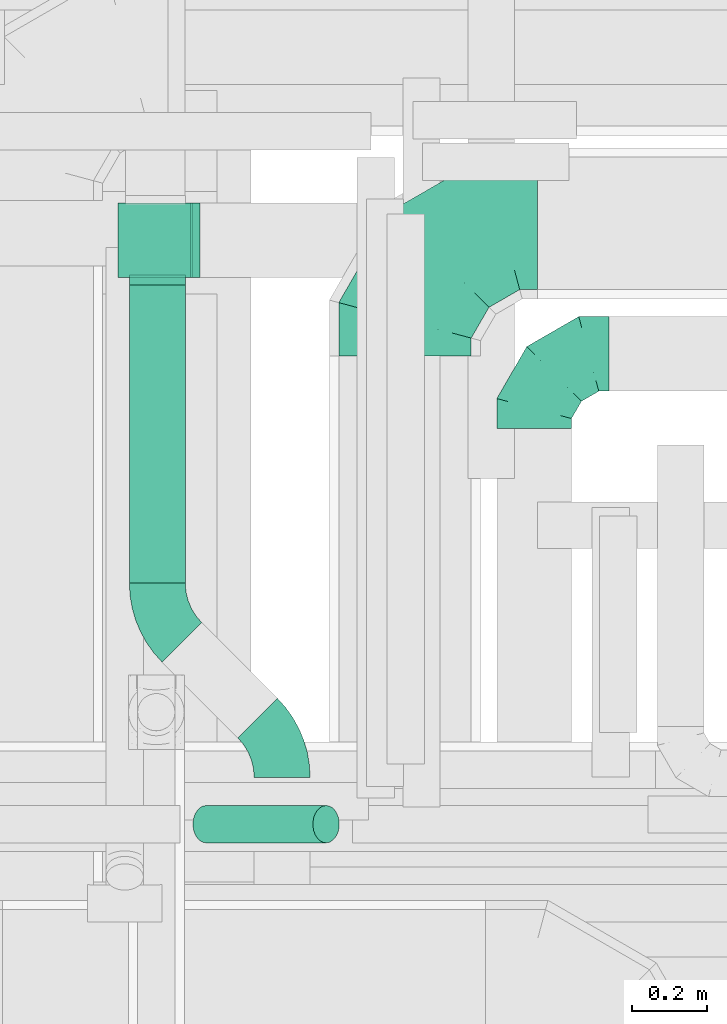
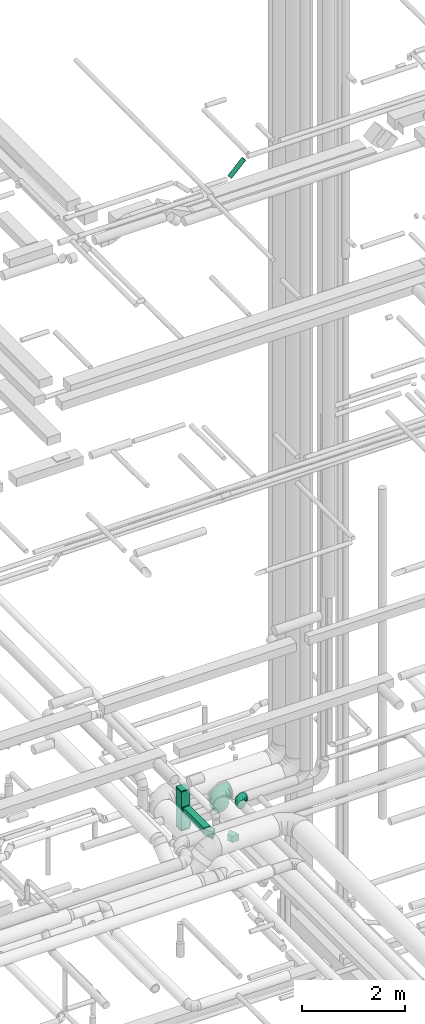
# One storey, part 256 of 337: 8 flow fittings, 3 flow segments.
"""IFC2X3 building model written with IfcOpenShell, lengths in millimetres."""

import ifcopenshell
import ifcopenshell.guid

model = None  # the IFC model being written
_history = None  # IfcOwnerHistory: only IFC2X3 demands one
_inside = {}  # id of a spatial element -> (the spatial element, [elements in it])
_under = {}  # id of a project, library or spatial element -> (it, [spatial elements below it])
_declared = {}  # id of a project -> (the project, [libraries it declares])
_typed = {}  # id of a type object -> (the type object, [elements of that type])
_made_of = {}  # id of a material, layer set ... -> (it, [elements and type objects made of it])


def new_model(schema):
    """Start an empty IFC model of exactly this schema.

    Asked for "IFC4X3", IfcOpenShell would pick the latest addendum, in which some entities
    have other attributes; the version numbers below select the first issue.
    IFC2X3 requires an IfcOwnerHistory on every rooted entity: one is made here for all.
    """
    global model, _history
    if schema == "IFC4X3":
        model = ifcopenshell.file(schema_version=(4, 3, 0, 0))
    else:
        model = ifcopenshell.file(schema=schema)
    _inside.clear()
    _under.clear()
    _declared.clear()
    _typed.clear()
    _made_of.clear()
    _history = None
    if model.schema == "IFC2X3":
        org = make("IfcOrganization", Name="unknown")
        user = make(
            "IfcPersonAndOrganization",
            ThePerson=make("IfcPerson", FamilyName="unknown"),
            TheOrganization=org,
        )
        app = make(
            "IfcApplication",
            ApplicationDeveloper=org,
            Version="unknown",
            ApplicationFullName="unknown",
            ApplicationIdentifier="unknown",
        )
        _history = make(
            "IfcOwnerHistory",
            OwningUser=user,
            OwningApplication=app,
            ChangeAction="ADDED",
            CreationDate=0,
        )
    return model


def make(cls, **values):
    """One entity of the class cls with the attributes given. An attribute that is None is left unset."""
    return model.create_entity(
        cls, **{name: value for name, value in values.items() if value is not None}
    )


def entity(cls, *values):
    """Any entity or typed value of the class cls, its attributes in the order of the schema. None: left unset."""
    e = model.create_entity(cls)
    for i, value in enumerate(values):
        if value is not None:
            e[i] = value
    return e


def rooted(cls, **values):
    """An entity with a GlobalId (a new one), such as an element, a storey or a relation."""
    return make(cls, GlobalId=ifcopenshell.guid.new(), OwnerHistory=_history, **values)


def si_unit(unit_type, name, prefix=None):
    """IfcSIUnit, for example si_unit("LENGTHUNIT", "METRE", prefix="MILLI")."""
    return make("IfcSIUnit", UnitType=unit_type, Prefix=prefix, Name=name)


def converted_unit(unit_type, name, factor, base, dimensions=None, offset=None):
    """IfcConversionBasedUnit, such as the inch: factor (a typed value) times the base unit."""
    return make(
        "IfcConversionBasedUnit"
        if offset is None
        else "IfcConversionBasedUnitWithOffset",
        ConversionOffset=offset,
        Dimensions=None
        if dimensions is None
        else entity("IfcDimensionalExponents", *dimensions),
        UnitType=unit_type,
        Name=name,
        ConversionFactor=make(
            "IfcMeasureWithUnit", ValueComponent=factor, UnitComponent=base
        ),
    )


def derived_unit(unit_type, elements):
    """IfcDerivedUnit: a product of units, each with its exponent."""
    return make(
        "IfcDerivedUnit",
        Elements=[
            make("IfcDerivedUnitElement", Unit=unit, Exponent=power)
            for unit, power in elements
        ],
        UnitType=unit_type,
    )


def assignment(units):
    """IfcUnitAssignment: the units of a project."""
    return None if units is None else make("IfcUnitAssignment", Units=units)


def point(xyz):
    """IfcCartesianPoint."""
    return None if xyz is None else make("IfcCartesianPoint", Coordinates=xyz)


def direction(xyz):
    """IfcDirection."""
    return None if xyz is None else make("IfcDirection", DirectionRatios=xyz)


def frame(location, z_axis=None, x_axis=None):
    """IfcAxis2Placement3D, a coordinate frame: its origin and axes. An axis left out is left unset."""
    return make(
        "IfcAxis2Placement3D",
        Location=point(location),
        Axis=direction(z_axis),
        RefDirection=direction(x_axis),
    )


def frame_2d(location, x_axis=None):
    """IfcAxis2Placement2D, a coordinate frame in the plane: its origin and x axis."""
    return make(
        "IfcAxis2Placement2D", Location=point(location), RefDirection=direction(x_axis)
    )


def origin():
    """The frame at (0, 0, 0) with its axes left unset."""
    return frame((0.0, 0.0, 0.0))


def origin_2d_with_axis():
    """The frame at (0, 0) in the plane with the x axis (1, 0) written out."""
    return frame_2d((0.0, 0.0), x_axis=(1.0, 0.0))


def place(relative_to, where):
    """IfcLocalPlacement: puts the frame where relative to a parent placement (None: the world)."""
    return make(
        "IfcLocalPlacement", PlacementRelTo=relative_to, RelativePlacement=where
    )


def context(
    kind, dimensions, precision=None, world=None, true_north=None, identifier=None
):
    """IfcGeometricRepresentationContext, for example the 3D "Model" context."""
    return make(
        "IfcGeometricRepresentationContext",
        ContextIdentifier=identifier,
        ContextType=kind,
        CoordinateSpaceDimension=dimensions,
        Precision=precision,
        WorldCoordinateSystem=world,
        TrueNorth=true_north,
    )


def subcontext(parent, identifier, kind, view, scale=None):
    """IfcGeometricRepresentationSubContext, for example "Body" below "Model"."""
    return make(
        "IfcGeometricRepresentationSubContext",
        ContextIdentifier=identifier,
        ContextType=kind,
        ParentContext=parent,
        TargetScale=scale,
        TargetView=view,
    )


def project(units=None, contexts=None):
    """IfcProject with its units and contexts."""
    return rooted(
        "IfcProject",
        Name="project",
        RepresentationContexts=contexts,
        UnitsInContext=assignment(units),
    )


def spatial(cls, under=None, at=None, **own):
    """A site, building, storey or space (cls), placed at a placement, below another one or the project."""
    s = rooted(cls, ObjectPlacement=at, **own)
    if under is not None:
        _under.setdefault(under.id(), (under, []))[1].append(s)
    return s


def polyline(points):
    """IfcPolyline through the points."""
    return make("IfcPolyline", Points=[point(p) for p in points])


def circle_curve(where, radius):
    """IfcCircle in the frame where."""
    return make("IfcCircle", Position=where, Radius=radius)


def parameter(value):
    """IfcParameterValue: where a trimmed curve begins or ends, as a parameter of its basis curve."""
    return model.create_entity("IfcParameterValue", value)


def trimmed(basis, trim1, trim2, sense, master):
    """IfcTrimmedCurve: the piece of a basis curve between two trims."""
    return make(
        "IfcTrimmedCurve",
        BasisCurve=basis,
        Trim1=trim1,
        Trim2=trim2,
        SenseAgreement=sense,
        MasterRepresentation=master,
    )


def segment(curve, same_sense, transition):
    """IfcCompositeCurveSegment."""
    return make(
        "IfcCompositeCurveSegment",
        Transition=transition,
        SameSense=same_sense,
        ParentCurve=curve,
    )


def composite_curve(segments, self_intersect=None):
    """IfcCompositeCurve: segments joined end to end."""
    return make("IfcCompositeCurve", Segments=segments, SelfIntersect=self_intersect)


def profile(cls, at=None, kind="AREA", **sizes):
    """A parametric profile (cls). Its sizes go by their IFC names, for example OverallWidth=200.0."""
    return make(cls, ProfileType=kind, Position=at, **sizes)


def rectangle(**sizes):
    """IfcRectangleProfileDef."""
    return profile("IfcRectangleProfileDef", **sizes)


def circle(**sizes):
    """IfcCircleProfileDef."""
    return profile("IfcCircleProfileDef", **sizes)


def outline(outer, holes=None, kind="AREA"):
    """IfcArbitraryClosedProfileDef: a profile drawn as a closed curve; with holes, ...WithVoids."""
    if holes is None:
        return make("IfcArbitraryClosedProfileDef", ProfileType=kind, OuterCurve=outer)
    return make(
        "IfcArbitraryProfileDefWithVoids",
        ProfileType=kind,
        OuterCurve=outer,
        InnerCurves=holes,
    )


def extrude(swept, where, along, depth):
    """IfcExtrudedAreaSolid: the profile swept, set in the frame where, extruded along a direction by depth."""
    return make(
        "IfcExtrudedAreaSolid",
        SweptArea=swept,
        Position=where,
        ExtrudedDirection=direction(along),
        Depth=depth,
    )


def faces_of(points, faces, orient=None, outer=None):
    """IfcFace entities. A face is a list of loops; a loop is a list of indices into points, from 0.

    orient and outer hold one flag for each loop. By default every Orientation is true, the
    first loop of a face is its IfcFaceOuterBound and the others are IfcFaceBound.
    """
    made = []
    for i, loops in enumerate(faces):
        bounds = []
        for j, loop in enumerate(loops):
            is_outer = j == 0 if outer is None else outer[i][j]
            bounds.append(
                make(
                    "IfcFaceOuterBound" if is_outer else "IfcFaceBound",
                    Bound=make("IfcPolyLoop", Polygon=[points[k] for k in loop]),
                    Orientation=True if orient is None else orient[i][j],
                )
            )
        made.append(make("IfcFace", Bounds=bounds))
    return made


def faceted_brep(points, faces, orient=None, outer=None, voids=None):
    """IfcFacetedBrep: a solid bounded by flat faces; with voids (closed shells), ...WithVoids."""
    shared = [point(p) for p in points]
    hull = make("IfcClosedShell", CfsFaces=faces_of(shared, faces, orient, outer))
    if voids is None:
        return make("IfcFacetedBrep", Outer=hull)
    return make(
        "IfcFacetedBrepWithVoids",
        Outer=hull,
        Voids=[
            make(cls, CfsFaces=faces_of(shared, fs, o, b)) for cls, fs, o, b in voids
        ],
    )


def shape(context_of_items, identifier, shape_type, items):
    """IfcShapeRepresentation: the items that make up one representation, for example the "Body"."""
    return make(
        "IfcShapeRepresentation",
        ContextOfItems=context_of_items,
        RepresentationIdentifier=identifier,
        RepresentationType=shape_type,
        Items=items,
    )


def source(mapping_origin, context_of_items, identifier, shape_type, items):
    """IfcRepresentationMap: a shape defined once, which mapped items show again and again."""
    return make(
        "IfcRepresentationMap",
        MappingOrigin=mapping_origin,
        MappedRepresentation=shape(context_of_items, identifier, shape_type, items),
    )


def transform(
    local_origin,
    x_axis=None,
    y_axis=None,
    z_axis=None,
    scale=None,
    scale2=None,
    scale3=None,
    uniform=True,
):
    """IfcCartesianTransformationOperator3D, or its non-uniform kind. x_axis, y_axis, z_axis: its Axis1, 2, 3."""
    if uniform:
        return make(
            "IfcCartesianTransformationOperator3D",
            Axis1=direction(x_axis),
            Axis2=direction(y_axis),
            LocalOrigin=point(local_origin),
            Scale=scale,
            Axis3=direction(z_axis),
        )
    return make(
        "IfcCartesianTransformationOperator3DnonUniform",
        Axis1=direction(x_axis),
        Axis2=direction(y_axis),
        LocalOrigin=point(local_origin),
        Scale=scale,
        Axis3=direction(z_axis),
        Scale2=scale2,
        Scale3=scale3,
    )


def mapped(mapping_source, mapping_target):
    """IfcMappedItem: shows the shape of a source again, moved by a transform."""
    return make(
        "IfcMappedItem", MappingSource=mapping_source, MappingTarget=mapping_target
    )


def material(Name=None, Category=None):
    """IfcMaterial."""
    return make("IfcMaterial", Name=Name, Category=Category)


def made_of(thing, what):
    """Note that an element or type object is made of a material, layer set ...; save() writes the relation."""
    if what is not None:
        _made_of.setdefault(what.id(), (what, []))[1].append(thing)
    return thing


def type_object(cls, material=None, **own):
    """A type object (cls), such as IfcWallType, which elements share."""
    return made_of(rooted(cls, **own), material)


def type_shapes(of_type, sources):
    """Give a type object the sources (RepresentationMaps) that its elements show as mapped items."""
    of_type.RepresentationMaps = sources


def element(
    cls,
    number,
    at=None,
    inside=None,
    cuts=None,
    type_object=None,
    material=None,
    context=None,
    identifier="Body",
    shape_type=None,
    held_by="IfcProductDefinitionShape",
    body=None,
    shapes=None,
    **own,
):
    """One element of the class cls, such as IfcWall. Its Tag is "e" and its number.

    at: its placement. inside: the storey or other place that contains it. cuts: it is an
    opening in that element (IfcRelVoidsElement). A single representation is given by context,
    identifier, shape_type and body (its items); several are given by shapes. held_by: the class
    of the entity that holds the representations. save() writes the other relations.
    """
    e = rooted(cls, Tag="e%d" % number, ObjectPlacement=at, **own)
    if body is not None:
        shapes = [shape(context, identifier, shape_type, body)]
    if shapes is not None:
        e.Representation = make(held_by, Representations=shapes)
    if inside is not None:
        _inside.setdefault(inside.id(), (inside, []))[1].append(e)
    if cuts is not None:
        rooted(
            "IfcRelVoidsElement", RelatingBuildingElement=cuts, RelatedOpeningElement=e
        )
    if type_object is not None:
        _typed.setdefault(type_object.id(), (type_object, []))[1].append(e)
    return made_of(e, material)


def aggregate(whole, parts):
    """IfcRelAggregates: a whole, such as a stair, and the parts it consists of."""
    return rooted("IfcRelAggregates", RelatingObject=whole, RelatedObjects=parts)


def save(model, path):
    """Write the relations noted so far, then the file.

    IfcRelAggregates (storeys below a building ...), IfcRelContainedInSpatialStructure (elements
    in a storey), IfcRelDefinesByType, IfcRelAssociatesMaterial and IfcRelDeclares: one each for
    every whole, place, type object, material and project.
    """
    for whole, parts in _under.values():
        aggregate(whole, parts)
    for where, things in _inside.values():
        rooted(
            "IfcRelContainedInSpatialStructure",
            RelatedElements=things,
            RelatingStructure=where,
        )
    for kind, things in _typed.values():
        rooted("IfcRelDefinesByType", RelatedObjects=things, RelatingType=kind)
    for what, things in _made_of.values():
        rooted("IfcRelAssociatesMaterial", RelatedObjects=things, RelatingMaterial=what)
    for by, libraries in _declared.values():
        rooted("IfcRelDeclares", RelatingContext=by, RelatedDefinitions=libraries)
    model.write(path)


model = new_model("IFC2X3")

# Units and contexts
model_context = context("Model", 3, precision=0.01, world=origin(), true_north=direction((6.12303176911189e-17, 1.0)))
body_context = subcontext(model_context, "Body", "Model", "MODEL_VIEW")
ifc_project = project(units=[si_unit("LENGTHUNIT", "METRE", prefix="MILLI"), si_unit("AREAUNIT", "SQUARE_METRE"), si_unit("VOLUMEUNIT", "CUBIC_METRE"), converted_unit("PLANEANGLEUNIT", "DEGREE", entity("IfcRatioMeasure", 0.0174532925199433), si_unit("PLANEANGLEUNIT", "RADIAN"), dimensions=[0, 0, 0, 0, 0, 0, 0]), si_unit("MASSUNIT", "GRAM", prefix="KILO"), derived_unit("MASSDENSITYUNIT", [(si_unit("MASSUNIT", "GRAM", prefix="KILO"), 1), (si_unit("LENGTHUNIT", "METRE"), -3)]), derived_unit("MOMENTOFINERTIAUNIT", [(si_unit("LENGTHUNIT", "METRE"), 4)]), si_unit("TIMEUNIT", "SECOND"), si_unit("FREQUENCYUNIT", "HERTZ"), si_unit("THERMODYNAMICTEMPERATUREUNIT", "DEGREE_CELSIUS"), derived_unit("THERMALTRANSMITTANCEUNIT", [(si_unit("MASSUNIT", "GRAM", prefix="KILO"), 1), (si_unit("THERMODYNAMICTEMPERATUREUNIT", "KELVIN"), -1), (si_unit("TIMEUNIT", "SECOND"), -3)]), derived_unit("VOLUMETRICFLOWRATEUNIT", [(si_unit("LENGTHUNIT", "METRE"), 3), (si_unit("TIMEUNIT", "SECOND"), -1)]), derived_unit("MASSFLOWRATEUNIT", [(si_unit("MASSUNIT", "GRAM", prefix="KILO"), 1), (si_unit("TIMEUNIT", "SECOND"), -1)]), derived_unit("ROTATIONALFREQUENCYUNIT", [(si_unit("TIMEUNIT", "SECOND"), -1)]), si_unit("ELECTRICCURRENTUNIT", "AMPERE"), si_unit("ELECTRICVOLTAGEUNIT", "VOLT"), si_unit("POWERUNIT", "WATT"), si_unit("FORCEUNIT", "NEWTON", prefix="KILO"), si_unit("ILLUMINANCEUNIT", "LUX"), si_unit("LUMINOUSFLUXUNIT", "LUMEN"), si_unit("LUMINOUSINTENSITYUNIT", "CANDELA"), derived_unit("USERDEFINED", [(si_unit("MASSUNIT", "GRAM", prefix="KILO"), -1), (si_unit("LENGTHUNIT", "METRE"), -2), (si_unit("TIMEUNIT", "SECOND"), 3), (si_unit("LUMINOUSFLUXUNIT", "LUMEN"), 1)]), derived_unit("LINEARVELOCITYUNIT", [(si_unit("LENGTHUNIT", "METRE"), 1), (si_unit("TIMEUNIT", "SECOND"), -1)]), si_unit("PRESSUREUNIT", "PASCAL"), derived_unit("USERDEFINED", [(si_unit("LENGTHUNIT", "METRE"), -2), (si_unit("MASSUNIT", "GRAM", prefix="KILO"), 1), (si_unit("TIMEUNIT", "SECOND"), -2)]), derived_unit("LINEARFORCEUNIT", [(si_unit("MASSUNIT", "GRAM", prefix="KILO"), 1), (si_unit("LENGTHUNIT", "METRE"), 1), (si_unit("TIMEUNIT", "SECOND"), -2), (si_unit("LENGTHUNIT", "METRE"), -1)]), derived_unit("PLANARFORCEUNIT", [(si_unit("MASSUNIT", "GRAM", prefix="KILO"), 1), (si_unit("LENGTHUNIT", "METRE"), 1), (si_unit("TIMEUNIT", "SECOND"), -2), (si_unit("LENGTHUNIT", "METRE"), -2)])], contexts=[model_context])

# Site, building, storey
site_placement = place(None, origin())
site = spatial("IfcSite", under=ifc_project, at=site_placement, CompositionType="ELEMENT")
building_placement = place(site_placement, origin())
building = spatial("IfcBuilding", under=site, at=building_placement, CompositionType="ELEMENT")
storey_placement = place(building_placement, origin())
storey = spatial("IfcBuildingStorey", under=building, at=storey_placement, CompositionType="ELEMENT", Elevation=0.0)

# Flow segments
duct_segment_type_1 = type_object("IfcDuctSegmentType", PredefinedType="NOTDEFINED")
flow_segment_1_placement = place(storey_placement, frame((64944.49, 10825.35, 2975.0)))
element("IfcFlowSegment", 1, at=flow_segment_1_placement, inside=storey, type_object=duct_segment_type_1, context=body_context, shape_type="SweptSolid", body=[
    extrude(rectangle(XDim=798.935128142338, YDim=150.000000000001, at=origin_2d_with_axis()), frame((75.0, 399.47, 0.0), z_axis=(0.0, 0.0, 1.0), x_axis=(0.0, 1.0, 0.0)), (0.0, 0.0, 1.0), 150.000000000001),
])
flow_segment_2_placement = place(storey_placement, frame((64914.49, 11644.28, 2585.0)))
element("IfcFlowSegment", 2, at=flow_segment_2_placement, inside=storey, type_object=duct_segment_type_1, context=body_context, shape_type="SweptSolid", body=[
    extrude(rectangle(XDim=200.000000000007, YDim=200.0, at=origin_2d_with_axis()), frame((100.0, 100.0, 0.0)), (0.0, 0.0, 1.0), 900.0),
])
duct_segment_type_2 = type_object("IfcDuctSegmentType", PredefinedType="NOTDEFINED")
flow_segment_3_placement = place(storey_placement, frame((65113.4, 10127.45, 18812.34)))
element("IfcFlowSegment", 3, at=flow_segment_3_placement, inside=storey, type_object=duct_segment_type_2, context=body_context, shape_type="SweptSolid", body=[
    extrude(circle(Radius=50.0, at=origin_2d_with_axis()), frame((36.95, 51.6, 36.95), z_axis=(0.707106781186551, 0.0, 0.707106781186544), x_axis=(0.0, 1.0, 0.0)), (0.0, 0.0, 1.0), 454.55844122714),
])

# Flow fittings
ifc_material = material()
duct_fitting_type_1 = type_object("IfcDuctFittingType", PredefinedType="NOTDEFINED", material=ifc_material)
shared_shape_1 = source(origin(), body_context, "Body", "SweptSolid", [
    extrude(rectangle(XDim=26.0960000000062, YDim=150.0, at=origin_2d_with_axis()), frame((6.95, 0.0, -75.0)), (0.0, 0.0, 1.0), 150.0),
])
type_shapes(duct_fitting_type_1, [shared_shape_1])
flow_fitting_1_placement = place(storey_placement, frame((65019.49, 11644.28, 3050.0), z_axis=(-1.0, 0.0, 0.0), x_axis=(0.0, -1.0, 0.0)))
element("IfcFlowFitting", 4, at=flow_fitting_1_placement, inside=storey, type_object=duct_fitting_type_1, material=ifc_material, context=body_context, shape_type="MappedRepresentation", body=[
    mapped(shared_shape_1, transform((0.0, 0.0, 0.0), scale=1.0)),
])
duct_fitting_type_2 = type_object("IfcDuctFittingType", PredefinedType="NOTDEFINED", material=ifc_material)
shared_shape_2 = source(origin(), body_context, "Body", "SweptSolid", [
    extrude(rectangle(XDim=26.0960000000436, YDim=200.0, at=origin_2d_with_axis()), frame((6.95, 0.0, -100.0)), (0.0, 0.0, 1.0), 200.0),
])
type_shapes(duct_fitting_type_2, [shared_shape_2])
flow_fitting_2_placement = place(storey_placement, frame((65114.49, 11744.28, 2700.0), z_axis=(0.0, -1.0, 0.0), x_axis=(1.0, 0.0, 0.0)))
element("IfcFlowFitting", 5, at=flow_fitting_2_placement, inside=storey, type_object=duct_fitting_type_2, material=ifc_material, context=body_context, shape_type="MappedRepresentation", body=[
    mapped(shared_shape_2, transform((0.0, 0.0, 0.0), scale=1.0)),
])
duct_fitting_type_3 = type_object("IfcDuctFittingType", PredefinedType="NOTDEFINED", material=ifc_material)
shared_shape_3 = source(origin(), body_context, "Body", "SweptSolid", [
    extrude(rectangle(XDim=24.9999999999999, YDim=200.0, at=origin_2d_with_axis()), frame((12.5, 0.0, -100.0)), (0.0, 0.0, 1.0), 200.0),
])
type_shapes(duct_fitting_type_3, [shared_shape_3])
for number, where, z_axis, x_axis in (
    (6, (65014.49, 11744.28, 2585.0), (1.0, 0.0, 0.0), (0.0, 0.0, -1.0)),
    (7, (65014.49, 11744.28, 3485.0), (1.0, 0.0, 0.0), (0.0, 0.0, 1.0)),
):
    element("IfcFlowFitting", number, at=place(storey_placement, frame(where, z_axis=z_axis, x_axis=x_axis)), inside=storey, type_object=duct_fitting_type_3, material=ifc_material, context=body_context, shape_type="MappedRepresentation", body=[
        mapped(shared_shape_3, transform((0.0, 0.0, 0.0), scale=1.0)),
    ])
duct_fitting_type_4 = type_object("IfcDuctFittingType", PredefinedType="NOTDEFINED", material=ifc_material)
shared_shape_4 = source(origin(), body_context, "Body", "Brep", [
    faceted_brep([(-200.0, 0.0, -100.0), (-200.0, -25.88, -96.59), (-200.0, -50.0, -86.6), (-200.0, -70.71, -70.71), (-200.0, -86.6, -50.0), (-200.0, -96.59, -25.88), (-200.0, -100.0, 0.0), (-200.0, -96.59, 25.88), (-200.0, -86.6, 50.0), (-200.0, -70.71, 70.71), (-200.0, -50.0, 86.6), (-200.0, -25.88, 96.59), (-200.0, 0.0, 100.0), (-200.0, 25.88, 96.59), (-200.0, 50.0, 86.6), (-200.0, 70.71, 70.71), (-200.0, 86.6, 50.0), (-200.0, 96.59, 25.88), (-200.0, 100.0, 0.0), (-200.0, 96.59, -25.88), (-200.0, 86.6, -50.0), (-200.0, 70.71, -70.71), (-200.0, 50.0, -86.6), (-200.0, 25.88, -96.59), (-153.35, 25.88, 96.59), (-159.81, 50.0, 86.6), (-146.41, 0.0, 100.0), (-165.36, 70.71, 70.71), (-172.29, 96.59, 25.88), (-173.21, 100.0, 0.0), (-169.62, 86.6, 50.0), (-169.62, 86.6, -50.0), (-165.36, 70.71, -70.71), (-172.29, 96.59, -25.88), (-153.35, 25.88, -96.59), (-146.41, 0.0, -100.0), (-159.81, 50.0, -86.6), (-139.48, -25.88, -96.59), (-133.01, -50.0, -86.6), (-127.46, -70.71, -70.71), (-123.21, -86.6, -50.0), (-120.53, -96.59, -25.88), (-119.62, -100.0, 0.0), (-120.53, -96.59, 25.88), (-123.21, -86.6, 50.0), (-127.46, -70.71, 70.71), (-133.01, -50.0, 86.6), (-139.48, -25.88, 96.59), (-72.54, 72.54, 96.59), (-90.19, 90.19, 86.6), (-53.59, 53.59, 100.0), (-105.35, 105.35, 70.71), (-116.99, 116.99, 50.0), (-124.3, 124.3, 25.88), (-126.79, 126.79, 0.0), (-124.3, 124.3, -25.88), (-116.99, 116.99, -50.0), (-105.35, 105.35, -70.71), (-72.54, 72.54, -96.59), (-53.59, 53.59, -100.0), (-90.19, 90.19, -86.6), (-34.64, 34.64, -96.59), (-16.99, 16.99, -86.6), (-1.83, 1.83, -70.71), (9.81, -9.81, -50.0), (17.12, -17.12, -25.88), (19.62, -19.62, 0.0), (17.12, -17.12, 25.88), (9.81, -9.81, 50.0), (-1.83, 1.83, 70.71), (-16.99, 16.99, 86.6), (-34.64, 34.64, 96.59), (-25.88, 153.35, 96.59), (-50.0, 159.81, 86.6), (0.0, 146.41, 100.0), (-70.71, 165.36, 70.71), (-86.6, 169.62, 50.0), (-96.59, 172.29, 25.88), (-100.0, 173.21, 0.0), (-96.59, 172.29, -25.88), (-86.6, 169.62, -50.0), (-70.71, 165.36, -70.71), (-25.88, 153.35, -96.59), (0.0, 146.41, -100.0), (-50.0, 159.81, -86.6), (25.88, 139.48, -96.59), (50.0, 133.01, -86.6), (70.71, 127.46, -70.71), (86.6, 123.21, -50.0), (96.59, 120.53, -25.88), (100.0, 119.62, 0.0), (96.59, 120.53, 25.88), (86.6, 123.21, 50.0), (70.71, 127.46, 70.71), (50.0, 133.01, 86.6), (25.88, 139.48, 96.59), (-25.88, 200.0, -96.59), (-50.0, 200.0, -86.6), (-70.71, 200.0, -70.71), (-86.6, 200.0, -50.0), (-96.59, 200.0, -25.88), (-100.0, 200.0, 0.0), (-96.59, 200.0, 25.88), (-86.6, 200.0, 50.0), (-70.71, 200.0, 70.71), (-50.0, 200.0, 86.6), (-25.88, 200.0, 96.59), (0.0, 200.0, 100.0), (25.88, 200.0, 96.59), (50.0, 200.0, 86.6), (70.71, 200.0, 70.71), (86.6, 200.0, 50.0), (96.59, 200.0, 25.88), (100.0, 200.0, 0.0), (96.59, 200.0, -25.88), (86.6, 200.0, -50.0), (70.71, 200.0, -70.71), (50.0, 200.0, -86.6), (25.88, 200.0, -96.59), (0.0, 200.0, -100.0)], [[[0, 1, 2, 3, 4, 5, 6, 7, 8, 9, 10, 11, 12, 13, 14, 15, 16, 17, 18, 19, 20, 21, 22, 23]], [[24, 25, 14, 13]], [[26, 24, 13, 12]], [[14, 25, 27, 15]], [[28, 29, 18, 17]], [[30, 28, 17, 16]], [[15, 27, 30, 16]], [[20, 31, 32, 21]], [[33, 31, 20, 19]], [[18, 29, 33, 19]], [[34, 35, 0, 23]], [[36, 34, 23, 22]], [[32, 36, 22, 21]], [[1, 0, 35, 37]], [[2, 1, 37, 38]], [[38, 39, 3, 2]], [[5, 4, 40, 41]], [[6, 5, 41, 42]], [[39, 40, 4, 3]], [[6, 42, 43, 7]], [[7, 43, 44, 8]], [[8, 44, 45, 9]], [[9, 45, 46, 10]], [[10, 46, 47, 11]], [[26, 12, 11, 47]], [[48, 49, 25, 24]], [[50, 48, 24, 26]], [[27, 25, 49, 51]], [[52, 53, 28, 30]], [[51, 52, 30, 27]], [[29, 28, 53, 54]], [[55, 56, 31, 33]], [[54, 55, 33, 29]], [[32, 31, 56, 57]], [[58, 59, 35, 34]], [[60, 58, 34, 36]], [[57, 60, 36, 32]], [[37, 35, 59, 61]], [[38, 37, 61, 62]], [[39, 38, 62, 63]], [[41, 40, 64, 65]], [[42, 41, 65, 66]], [[63, 64, 40, 39]], [[43, 42, 66, 67]], [[44, 43, 67, 68]], [[68, 69, 45, 44]], [[46, 45, 69, 70]], [[47, 46, 70, 71]], [[26, 47, 71, 50]], [[72, 73, 49, 48]], [[74, 72, 48, 50]], [[51, 49, 73, 75]], [[76, 77, 53, 52]], [[75, 76, 52, 51]], [[54, 53, 77, 78]], [[79, 80, 56, 55]], [[78, 79, 55, 54]], [[57, 56, 80, 81]], [[82, 83, 59, 58]], [[84, 82, 58, 60]], [[81, 84, 60, 57]], [[61, 59, 83, 85]], [[62, 61, 85, 86]], [[63, 62, 86, 87]], [[65, 64, 88, 89]], [[66, 65, 89, 90]], [[87, 88, 64, 63]], [[67, 66, 90, 91]], [[68, 67, 91, 92]], [[92, 93, 69, 68]], [[70, 69, 93, 94]], [[71, 70, 94, 95]], [[50, 71, 95, 74]], [[96, 97, 98, 99, 100, 101, 102, 103, 104, 105, 106, 107, 108, 109, 110, 111, 112, 113, 114, 115, 116, 117, 118, 119]], [[72, 74, 107, 106]], [[73, 72, 106, 105]], [[75, 73, 105, 104]], [[102, 101, 78, 77]], [[103, 102, 77, 76]], [[75, 104, 103, 76]], [[78, 101, 100, 79]], [[79, 100, 99, 80]], [[80, 99, 98, 81]], [[84, 97, 96, 82]], [[82, 96, 119, 83]], [[84, 81, 98, 97]], [[118, 117, 86, 85]], [[119, 118, 85, 83]], [[116, 87, 86, 117]], [[88, 115, 114, 89]], [[89, 114, 113, 90]], [[115, 88, 87, 116]], [[91, 90, 113, 112]], [[92, 91, 112, 111]], [[111, 110, 93, 92]], [[95, 94, 109, 108]], [[74, 95, 108, 107]], [[110, 109, 94, 93]]]),
])
type_shapes(duct_fitting_type_4, [shared_shape_4])
flow_fitting_3_placement = place(storey_placement, frame((66029.36, 11439.34, 3050.0), z_axis=(0.0, 0.0, 1.0), x_axis=(-1.0, 0.0, 0.0)))
element("IfcFlowFitting", 8, at=flow_fitting_3_placement, inside=storey, type_object=duct_fitting_type_4, material=ifc_material, context=body_context, shape_type="MappedRepresentation", body=[
    mapped(shared_shape_4, transform((0.0, 0.0, 0.0), scale=1.0)),
])
duct_fitting_type_5 = type_object("IfcDuctFittingType", PredefinedType="NOTDEFINED", material=ifc_material)
shared_shape_5 = source(origin(), body_context, "Body", "Brep", [
    faceted_brep([(-355.0, 0.0, -177.5), (-355.0, -45.94, -171.45), (-355.0, -88.75, -153.72), (-355.0, -125.51, -125.51), (-355.0, -153.72, -88.75), (-355.0, -171.45, -45.94), (-355.0, -177.5, 0.0), (-355.0, -171.45, 45.94), (-355.0, -153.72, 88.75), (-355.0, -125.51, 125.51), (-355.0, -88.75, 153.72), (-355.0, -45.94, 171.45), (-355.0, 0.0, 177.5), (-355.0, 45.94, 171.45), (-355.0, 88.75, 153.72), (-355.0, 125.51, 125.51), (-355.0, 153.72, 88.75), (-355.0, 171.45, 45.94), (-355.0, 177.5, 0.0), (-355.0, 171.45, -45.94), (-355.0, 153.72, -88.75), (-355.0, 125.51, -125.51), (-355.0, 88.75, -153.72), (-355.0, 45.94, -171.45), (-272.19, 45.94, 171.45), (-283.66, 88.75, 153.72), (-259.88, 0.0, 177.5), (-293.51, 125.51, 125.51), (-305.82, 171.45, 45.94), (-307.44, 177.5, 0.0), (-301.07, 153.72, 88.75), (-301.07, 153.72, -88.75), (-293.51, 125.51, -125.51), (-305.82, 171.45, -45.94), (-272.19, 45.94, -171.45), (-259.88, 0.0, -177.5), (-283.66, 88.75, -153.72), (-247.57, -45.94, -171.45), (-236.1, -88.75, -153.72), (-226.25, -125.51, -125.51), (-218.69, -153.72, -88.75), (-213.94, -171.45, -45.94), (-212.32, -177.5, 0.0), (-213.94, -171.45, 45.94), (-218.69, -153.72, 88.75), (-226.25, -125.51, 125.51), (-236.1, -88.75, 153.72), (-247.57, -45.94, 171.45), (-128.75, 128.75, 171.45), (-160.09, 160.09, 153.72), (-95.12, 95.12, 177.5), (-187.0, 187.0, 125.51), (-207.65, 207.65, 88.75), (-220.63, 220.63, 45.94), (-225.06, 225.06, 0.0), (-220.63, 220.63, -45.94), (-207.65, 207.65, -88.75), (-187.0, 187.0, -125.51), (-128.75, 128.75, -171.45), (-95.12, 95.12, -177.5), (-160.09, 160.09, -153.72), (-61.49, 61.49, -171.45), (-30.15, 30.15, -153.72), (-3.24, 3.24, -125.51), (17.41, -17.41, -88.75), (30.39, -30.39, -45.94), (34.82, -34.82, 0.0), (30.39, -30.39, 45.94), (17.41, -17.41, 88.75), (-3.24, 3.24, 125.51), (-30.15, 30.15, 153.72), (-61.49, 61.49, 171.45), (-45.94, 272.19, 171.45), (-88.75, 283.66, 153.72), (0.0, 259.88, 177.5), (-125.51, 293.51, 125.51), (-153.72, 301.07, 88.75), (-171.45, 305.82, 45.94), (-177.5, 307.44, 0.0), (-171.45, 305.82, -45.94), (-153.72, 301.07, -88.75), (-125.51, 293.51, -125.51), (-45.94, 272.19, -171.45), (0.0, 259.88, -177.5), (-88.75, 283.66, -153.72), (45.94, 247.57, -171.45), (88.75, 236.1, -153.72), (125.51, 226.25, -125.51), (153.72, 218.69, -88.75), (171.45, 213.94, -45.94), (177.5, 212.32, 0.0), (171.45, 213.94, 45.94), (153.72, 218.69, 88.75), (125.51, 226.25, 125.51), (88.75, 236.1, 153.72), (45.94, 247.57, 171.45), (-45.94, 355.0, -171.45), (-88.75, 355.0, -153.72), (-125.51, 355.0, -125.51), (-153.72, 355.0, -88.75), (-171.45, 355.0, -45.94), (-177.5, 355.0, 0.0), (-171.45, 355.0, 45.94), (-153.72, 355.0, 88.75), (-125.51, 355.0, 125.51), (-88.75, 355.0, 153.72), (-45.94, 355.0, 171.45), (0.0, 355.0, 177.5), (45.94, 355.0, 171.45), (88.75, 355.0, 153.72), (125.51, 355.0, 125.51), (153.72, 355.0, 88.75), (171.45, 355.0, 45.94), (177.5, 355.0, 0.0), (171.45, 355.0, -45.94), (153.72, 355.0, -88.75), (125.51, 355.0, -125.51), (88.75, 355.0, -153.72), (45.94, 355.0, -171.45), (0.0, 355.0, -177.5)], [[[0, 1, 2, 3, 4, 5, 6, 7, 8, 9, 10, 11, 12, 13, 14, 15, 16, 17, 18, 19, 20, 21, 22, 23]], [[24, 25, 14, 13]], [[26, 24, 13, 12]], [[14, 25, 27, 15]], [[28, 29, 18, 17]], [[30, 28, 17, 16]], [[15, 27, 30, 16]], [[20, 31, 32, 21]], [[33, 31, 20, 19]], [[18, 29, 33, 19]], [[34, 35, 0, 23]], [[36, 34, 23, 22]], [[32, 36, 22, 21]], [[1, 0, 35, 37]], [[2, 1, 37, 38]], [[38, 39, 3, 2]], [[5, 4, 40, 41]], [[6, 5, 41, 42]], [[39, 40, 4, 3]], [[6, 42, 43, 7]], [[7, 43, 44, 8]], [[8, 44, 45, 9]], [[9, 45, 46, 10]], [[10, 46, 47, 11]], [[26, 12, 11, 47]], [[48, 49, 25, 24]], [[50, 48, 24, 26]], [[27, 25, 49, 51]], [[52, 53, 28, 30]], [[51, 52, 30, 27]], [[29, 28, 53, 54]], [[55, 56, 31, 33]], [[54, 55, 33, 29]], [[32, 31, 56, 57]], [[58, 59, 35, 34]], [[60, 58, 34, 36]], [[57, 60, 36, 32]], [[37, 35, 59, 61]], [[38, 37, 61, 62]], [[39, 38, 62, 63]], [[41, 40, 64, 65]], [[42, 41, 65, 66]], [[63, 64, 40, 39]], [[43, 42, 66, 67]], [[44, 43, 67, 68]], [[68, 69, 45, 44]], [[46, 45, 69, 70]], [[47, 46, 70, 71]], [[26, 47, 71, 50]], [[72, 73, 49, 48]], [[74, 72, 48, 50]], [[51, 49, 73, 75]], [[76, 77, 53, 52]], [[75, 76, 52, 51]], [[54, 53, 77, 78]], [[79, 80, 56, 55]], [[78, 79, 55, 54]], [[57, 56, 80, 81]], [[82, 83, 59, 58]], [[84, 82, 58, 60]], [[81, 84, 60, 57]], [[61, 59, 83, 85]], [[62, 61, 85, 86]], [[63, 62, 86, 87]], [[65, 64, 88, 89]], [[66, 65, 89, 90]], [[87, 88, 64, 63]], [[67, 66, 90, 91]], [[68, 67, 91, 92]], [[92, 93, 69, 68]], [[70, 69, 93, 94]], [[71, 70, 94, 95]], [[50, 71, 95, 74]], [[96, 97, 98, 99, 100, 101, 102, 103, 104, 105, 106, 107, 108, 109, 110, 111, 112, 113, 114, 115, 116, 117, 118, 119]], [[72, 74, 107, 106]], [[73, 72, 106, 105]], [[75, 73, 105, 104]], [[77, 76, 103, 102]], [[78, 77, 102, 101]], [[104, 103, 76, 75]], [[78, 101, 100, 79]], [[79, 100, 99, 80]], [[98, 81, 80, 99]], [[84, 97, 96, 82]], [[82, 96, 119, 83]], [[97, 84, 81, 98]], [[83, 119, 118, 85]], [[85, 118, 117, 86]], [[116, 87, 86, 117]], [[88, 115, 114, 89]], [[89, 114, 113, 90]], [[115, 88, 87, 116]], [[91, 90, 113, 112]], [[92, 91, 112, 111]], [[111, 110, 93, 92]], [[95, 94, 109, 108]], [[74, 95, 108, 107]], [[110, 109, 94, 93]]]),
])
type_shapes(duct_fitting_type_5, [shared_shape_5])
flow_fitting_4_placement = place(storey_placement, frame((65683.23, 11789.15, 3050.0), z_axis=(0.0, 0.0, 1.0), x_axis=(-1.0, 0.0, 0.0)))
element("IfcFlowFitting", 9, at=flow_fitting_4_placement, inside=storey, type_object=duct_fitting_type_5, material=ifc_material, context=body_context, shape_type="MappedRepresentation", body=[
    mapped(shared_shape_5, transform((0.0, 0.0, 0.0), scale=1.0)),
])
duct_fitting_type_6 = type_object("IfcDuctFittingType", PredefinedType="NOTDEFINED", material=ifc_material)
shared_shape_6 = source(origin(), body_context, "Body", "SweptSolid", [
    extrude(outline(composite_curve([segment(polyline([(-107.95, -79.55), (42.05, -79.55)]), True, "CONTINUOUS"), segment(trimmed(circle_curve(frame_2d((192.05, -79.55), x_axis=(-0.707106781186546, 0.707106781186546)), 150.0), [parameter(0.0)], [parameter(45.0)], True, "PARAMETER"), False, "CONTINUOUS"), segment(polyline([(85.98, 26.52), (-20.08, 132.58)]), True, "CONTINUOUS"), segment(trimmed(circle_curve(frame_2d((192.05, -79.55), x_axis=(-0.707106781186546, 0.707106781186546)), 300.0), [parameter(0.0)], [parameter(45.0)], True, "PARAMETER"), True, "CONTINUOUS")], self_intersect=False)), frame((-13.65, 32.95, -75.0), z_axis=(0.0, 0.0, 1.0), x_axis=(-0.707106781186547, 0.707106781186548, 0.0)), (0.0, 0.0, 1.0), 150.0),
])
type_shapes(duct_fitting_type_6, [shared_shape_6])
for number, where, z_axis, x_axis in (
    (10, (65354.05, 10397.59, 3050.0), (0.0, 0.0, 1.0), (0.0, 1.0, 0.0)),
    (11, (65019.49, 10732.15, 3050.0), (0.0, 0.0, 1.0), (0.0, -1.0, 0.0)),
):
    element("IfcFlowFitting", number, at=place(storey_placement, frame(where, z_axis=z_axis, x_axis=x_axis)), inside=storey, type_object=duct_fitting_type_6, material=ifc_material, context=body_context, shape_type="MappedRepresentation", body=[
        mapped(shared_shape_6, transform((0.0, 0.0, 0.0), scale=1.0)),
    ])

save(model, "model.ifc")
